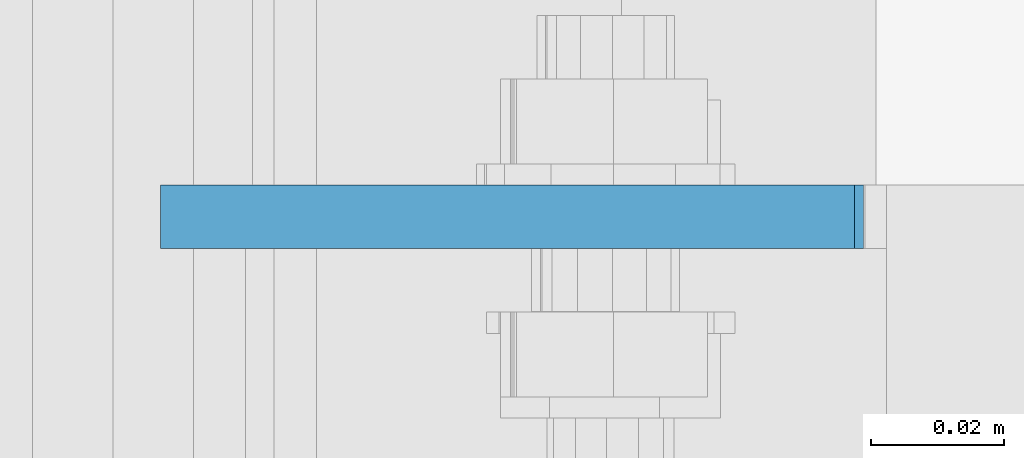
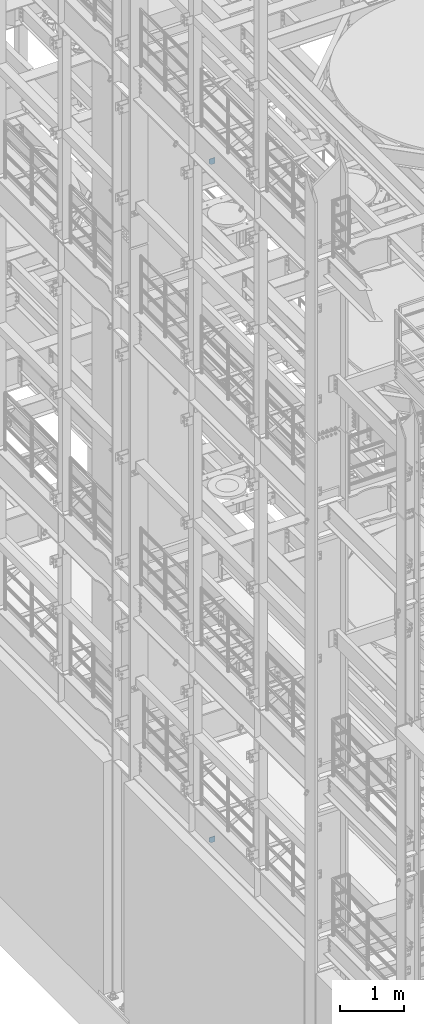
# One storey, part 1533 of 1876: 2 plates, 2 elements without a shape of their own.
"""IFC2X3 building model written with IfcOpenShell, lengths in millimetres."""

from ifc_helpers import new_model, si_unit, frame, origin_with_axes, place, context, subcontext, project, spatial, faceted_brep, material, type_object, element, aggregate, save


model = new_model("IFC2X3")

# Units and contexts
model_context = context("Model", 3, precision=1e-05, world=origin_with_axes())
body_context = subcontext(model_context, "Body", "Model", "MODEL_VIEW")
ifc_project = project(units=[si_unit("LENGTHUNIT", "METRE", prefix="MILLI"), si_unit("AREAUNIT", "SQUARE_METRE"), si_unit("VOLUMEUNIT", "CUBIC_METRE"), si_unit("MASSUNIT", "GRAM", prefix="KILO"), si_unit("TIMEUNIT", "SECOND"), si_unit("PLANEANGLEUNIT", "RADIAN"), si_unit("SOLIDANGLEUNIT", "STERADIAN"), si_unit("THERMODYNAMICTEMPERATUREUNIT", "DEGREE_CELSIUS"), si_unit("LUMINOUSINTENSITYUNIT", "LUMEN")], contexts=[model_context])

# Site, building, storey
site_placement = place(None, origin_with_axes())
site = spatial("IfcSite", under=ifc_project, at=site_placement, CompositionType="ELEMENT")
building_placement = place(site_placement, origin_with_axes())
building = spatial("IfcBuilding", under=site, at=building_placement, Name="Undefined", CompositionType="ELEMENT")
storey_placement = place(building_placement, origin_with_axes())
storey = spatial("IfcBuildingStorey", under=building, at=storey_placement, Name="Undefined", CompositionType="ELEMENT", Elevation=0.0)

# Assembly, plate
assembly_1_placement = place(storey_placement, origin_with_axes())
assembly_1 = element("IfcElementAssembly", 1, at=assembly_1_placement, inside=storey, Name="BEAM", AssemblyPlace="NOTDEFINED", PredefinedType="RIGID_FRAME")
ifc_material = material(Name="STEEL/A36")
plate_type_1 = type_object("IfcPlateType", PredefinedType="NOTDEFINED")
plate_1_placement = place(assembly_1_placement, frame((111.128498160898, -919.162499999999, 17386.3), z_axis=(-1.0, 0.0, 0.0), x_axis=(0.0, 0.0, 1.0)))
plate_1 = element("IfcPlate", 2, at=plate_1_placement, type_object=plate_type_1, material=ifc_material, Name="PLATE", context=body_context, shape_type="Brep", body=[
    faceted_brep([(0.0, -4.76249999999982, 0.0), (0.0, -4.76249999999982, 72.234748840332), (0.0, 4.76249999999982, 72.234748840332), (0.0, 4.76249999999982, 0.0), (31.75, -4.76249999999982, 103.984748840332), (31.75, 4.76249999999982, 103.984748840332), (111.653274536133, -4.76249999999982, 103.984748840332), (111.653274536133, 4.76249999999982, 103.984748840332), (111.653274536133, -4.76249999999982, 0.0), (111.653274536133, 4.76249999999982, 0.0)], [[[0, 1, 2, 3]], [[1, 4, 5, 2]], [[4, 6, 7, 5]], [[6, 8, 9, 7]], [[8, 0, 3, 9]], [[5, 7, 9, 3, 2]], [[8, 6, 4, 1, 0]]]),
])
aggregate(assembly_1, [plate_1])

assembly_2_placement = place(storey_placement, origin_with_axes())
assembly_2 = element("IfcElementAssembly", 3, at=assembly_2_placement, inside=storey, Name="BEAM", AssemblyPlace="NOTDEFINED", PredefinedType="RIGID_FRAME")
plate_type_2 = type_object("IfcPlateType", PredefinedType="NOTDEFINED")
plate_2_placement = place(assembly_2_placement, frame((112.451000275038, -919.162500000001, 4637.38699830036), z_axis=(0.0, 0.0, -1.0), x_axis=(-1.0, 0.0, 0.0)))
plate_2 = element("IfcPlate", 4, at=plate_2_placement, type_object=plate_type_2, material=ifc_material, Name="PLATE", context=body_context, shape_type="Brep", body=[
    faceted_brep([(0.0, -4.76249999999982, 0.0), (0.0, -4.76249999999999, 103.486999511719), (0.0, 4.76249999999999, 103.486999511719), (0.0, 4.76249999999982, 0.0), (73.5572509765625, -4.76249999999999, 103.486999511719), (73.5572509765625, 4.76249999999999, 103.486999511719), (105.307250976562, -4.76249999999999, 71.7369995117188), (105.307250976562, 4.76249999999999, 71.7369995117188), (105.307250976562, -4.76249999999999, 0.0), (105.307250976562, 4.76249999999999, 0.0)], [[[0, 1, 2, 3]], [[1, 4, 5, 2]], [[4, 6, 7, 5]], [[6, 8, 9, 7]], [[8, 0, 3, 9]], [[5, 7, 9, 3, 2]], [[8, 6, 4, 1, 0]]]),
])
aggregate(assembly_2, [plate_2])

save(model, "model.ifc")
